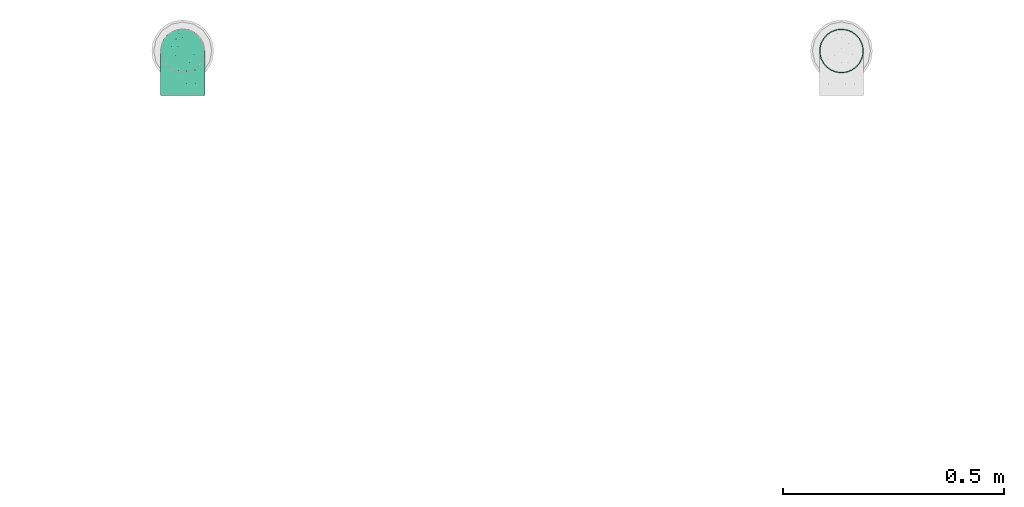
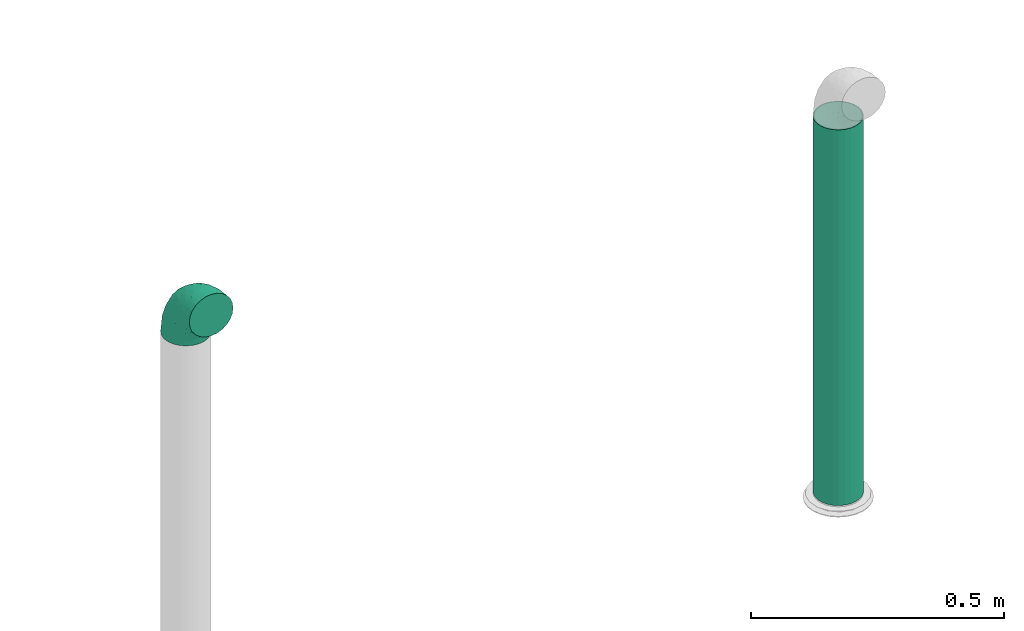
# One storey, part 77 of 103: 1 flow fitting, 1 flow segment.
"""IFC2X3 building model written with IfcOpenShell, lengths in millimetres."""

from ifc_helpers import new_model, entity, si_unit, converted_unit, derived_unit, direction, frame, origin_with_axes, origin_2d_with_axis, place, context, subcontext, project, spatial, hollow_circle, extrude, open_shell, surface_model, source, transform, mapped, material, layer, layer_set, layer_usage, type_object, element, save


model = new_model("IFC2X3")

# Units and contexts
model_context = context("Model", 3, precision=1e-05, world=origin_with_axes(), true_north=direction((0.0, 1.0)))
body_context = subcontext(model_context, "Body", "Model", "MODEL_VIEW")
ifc_project = project(units=[si_unit("AREAUNIT", "SQUARE_METRE"), si_unit("VOLUMEUNIT", "CUBIC_METRE", prefix="DECI"), si_unit("TIMEUNIT", "SECOND"), si_unit("THERMODYNAMICTEMPERATUREUNIT", "DEGREE_CELSIUS"), si_unit("PRESSUREUNIT", "PASCAL"), si_unit("MASSUNIT", "GRAM", prefix="KILO"), si_unit("LENGTHUNIT", "METRE", prefix="MILLI"), si_unit("POWERUNIT", "WATT"), si_unit("ELECTRICCURRENTUNIT", "AMPERE"), si_unit("ELECTRICVOLTAGEUNIT", "VOLT"), derived_unit("VOLUMETRICFLOWRATEUNIT", [(si_unit("VOLUMEUNIT", "CUBIC_METRE", prefix="DECI"), 1), (si_unit("TIMEUNIT", "SECOND"), -1)]), derived_unit("LINEARVELOCITYUNIT", [(si_unit("LENGTHUNIT", "METRE"), 1), (si_unit("TIMEUNIT", "SECOND"), -1)]), derived_unit("MASSDENSITYUNIT", [(si_unit("MASSUNIT", "GRAM", prefix="KILO"), 1), (si_unit("VOLUMEUNIT", "CUBIC_METRE"), -1)]), converted_unit("PLANEANGLEUNIT", "DEGREE", entity("IfcRatioMeasure", 0.01745), si_unit("PLANEANGLEUNIT", "RADIAN"), dimensions=[0, 0, 0, 0, 0, 0, 0])], contexts=[model_context])

# Site, building, storey
site_placement = place(None, origin_with_axes())
site = spatial("IfcSite", under=ifc_project, at=site_placement, CompositionType="ELEMENT")
building_placement = place(site_placement, origin_with_axes())
building = spatial("IfcBuilding", under=site, at=building_placement, Name="mc-building", CompositionType="ELEMENT")
storey_placement = place(building_placement, frame((0.0, 0.0, 5900.0), z_axis=(0.0, 0.0, 1.0), x_axis=(1.0, 0.0, 0.0)))
storey = spatial("IfcBuildingStorey", under=building, at=storey_placement, Name="3. Korrus", CompositionType="ELEMENT", Elevation=5900.0)

# Flow fitting
duct_fitting_type = type_object("IfcDuctFittingType", Name="BU", PredefinedType="BEND")
shared_shape_1 = source(origin_with_axes(), body_context, "Body", "SurfaceModel", [
    surface_model("IfcShellBasedSurfaceModel", [(-100.0, 0.0, -50.0), (-100.0, -12.94095, -48.29629), (-100.0, 12.94095, -48.29629), (-100.0, 48.29629, 12.94095), (-100.0, 25.0, -43.30127), (-100.0, 43.30127, -25.0), (-100.0, 35.35534, -35.35534), (-100.0, -50.0, 0.0), (-100.0, -48.29629, 12.94095), (-100.0, -35.35534, -35.35534), (-100.0, -25.0, -43.30127), (-100.0, -48.29629, -12.94095), (-100.0, -43.30127, -25.0), (-100.0, 48.29629, -12.94095), (-100.0, 43.30127, 25.0), (-100.0, 35.35534, 35.35534), (-100.0, -12.94095, 48.29629), (-100.0, 25.0, 43.30127), (-100.0, 12.94095, 48.29629), (-100.0, -43.30127, 25.0), (-100.0, -35.35534, 35.35534), (-100.0, -25.0, 43.30127), (-100.0, 0.0, 50.0), (-100.0, 50.0, 0.0), (-12.94095, 100.0, -48.29629), (-50.0, 100.0, 0.0), (0.0, 100.0, -50.0), (-25.0, 100.0, -43.30127), (-35.35534, 100.0, -35.35534), (-43.30127, 100.0, -25.0), (35.35534, 100.0, -35.35534), (48.29629, 100.0, 12.94095), (25.0, 100.0, -43.30127), (12.94095, 100.0, -48.29629), (43.30127, 100.0, -25.0), (48.29629, 100.0, -12.94095), (50.0, 100.0, 0.0), (-48.29629, 100.0, -12.94095), (-48.29629, 100.0, 12.94095), (-43.30127, 100.0, 25.0), (-35.35534, 100.0, 35.35534), (0.0, 100.0, 50.0), (-25.0, 100.0, 43.30127), (-12.94095, 100.0, 48.29629), (43.30127, 100.0, 25.0), (35.35534, 100.0, 35.35534), (25.0, 100.0, 43.30127), (12.94095, 100.0, 48.29629), (-58.37939, 44.26324, 39.66767), (-69.67318, 34.70921, 41.41807), (-54.95374, 29.60867, 47.22379), (-69.0983, 4.89435, 50.0), (-81.95957, 10.85813, 49.17398), (-71.45436, 24.34004, 46.19398), (-63.80701, 16.86512, 49.12211), (-68.68567, 49.28345, 29.46598), (-84.79657, 41.61468, 30.43807), (-87.38486, 20.12422, 46.19398), (-19.0983, 41.22148, 50.0), (-16.69326, 64.07661, 49.13167), (-29.12893, 54.21835, 47.49497), (-58.07867, 67.98053, 16.35576), (-67.87621, 57.34916, 18.11021), (-57.82431, 60.07162, 27.24983), (-90.54273, 47.92896, 16.84479), (-84.64671, 51.44953, 9.54872), (-89.28706, 52.13093, 0.0), (-48.57141, 84.18266, 19.13417), (-80.49866, 49.85236, 19.13417), (-10.78328, 82.03604, 49.18466), (-4.89435, 69.0983, 50.0), (-52.13093, 89.28706, 0.0), (-51.49654, 84.66157, 9.29171), (-41.22148, 19.0983, 50.0), (-40.55308, 40.55308, 47.39468), (-84.25895, 32.24248, 39.66767), (-20.22969, 86.73423, 46.19398), (-32.70712, 82.37816, 39.66767), (-39.73574, 63.26064, 40.42863), (-24.76101, 70.36257, 46.19398), (-52.07527, 72.10209, 22.70672), (-53.34351, 76.64659, 14.58596), (-75.39343, 54.87419, 11.74349), (-45.34852, 49.56196, 42.93091), (-67.79776, 60.76145, 8.68857), (-41.23466, 86.33892, 30.43807), (-53.80602, 80.86583, 0.0), (-46.83364, 71.48109, 30.43807), (-59.22534, 72.75524, 0.0), (-51.32111, 56.42251, 36.03223), (-80.86583, 53.80602, 0.0), (-64.64466, 64.64466, 0.0), (-72.75524, 59.22534, 0.0), (-86.30081, 41.24353, -30.43807), (-84.6487, 51.45583, -9.51467), (-90.59087, 47.99544, -16.6365), (-82.00387, 32.80624, -39.66767), (-72.72667, 42.3343, -34.47953), (-69.0983, 4.89435, -50.0), (-66.13967, 17.89682, -48.73206), (-41.22148, 19.0983, -50.0), (-19.92688, 59.20071, -48.9627), (-4.89435, 69.0983, -50.0), (-19.0983, 41.22148, -50.0), (-32.19887, 84.44786, -39.66767), (-82.82099, 10.02515, -49.28938), (-41.61468, 84.79657, -30.43807), (-82.27704, 21.1002, -46.19398), (-64.48049, 30.28903, -45.01594), (-71.3903, 57.59661, -10.6727), (-22.65007, 76.4146, -46.19398), (-80.71765, 49.76775, -19.13417), (-63.27201, 52.13514, -30.43807), (-66.69474, 56.78794, -20.8562), (-57.71875, 61.44646, -25.88117), (-51.44953, 84.64671, -9.54872), (-49.85236, 80.49866, -19.13417), (-49.18799, 68.95983, -29.38061), (-52.50869, 28.2692, -48.00802), (-47.92896, 90.54273, -16.84479), (-11.48103, 81.33005, -49.0827), (-31.33477, 60.4193, -45.4939), (-39.98518, 39.98518, -47.65708), (-59.80479, 65.98498, -16.07996), (-63.94971, 39.6845, -40.19955), (-52.24546, 47.26788, -40.83149), (-55.20497, 74.81068, -11.71424), (-38.49923, 67.49589, -39.66767), (-52.04722, 57.72873, -34.6201), (-73.59404, 48.69992, -26.65479), (-47.57173, 4.1387, -49.13473), (29.5722, 42.84907, -27.71428), (13.52969, 19.02651, -30.72245), (13.59601, 32.77977, -38.42312), (27.49134, 63.71843, -37.951), (17.59627, 59.41659, -43.64098), (-63.95523, -42.22253, -17.81382), (-42.84907, -29.5722, -27.71428), (-25.90272, -27.798, -14.9099), (-4.1387, 47.57173, -49.13473), (-20.45037, 20.45037, -48.41225), (-68.61243, -10.20497, -47.82471), (-73.92917, -46.87327, -9.07697), (-73.47057, -38.0442, -29.22414), (-63.71843, -27.49134, -37.951), (-32.77977, -13.59601, -38.42312), (-8.32573, -9.86545, -25.36336), (-59.41659, -17.59627, -43.64098), (10.20497, 68.61244, -47.82471), (3.58524, 39.93936, -45.93923), (-12.17948, 12.17948, -43.75507), (-39.93936, -3.58524, -45.93923), (44.88888, 61.17714, 0.0), (38.05536, 43.47505, -9.02401), (45.64165, 67.74269, -9.06645), (17.21028, 10.65055, -15.96581), (-25.0, -29.90381, 0.0), (-1.12135, -11.13977, -11.07369), (38.0442, 73.47057, -29.22414), (32.46004, 37.55825, -18.52941), (42.22253, 63.95523, -17.81382), (29.90381, 25.0, 0.0), (6.06602, -6.06602, 0.0), (-61.17714, -44.88888, 0.0), (-45.78423, -39.05041, -8.65056), (-4.97501, 4.97501, -36.29915), (-63.95523, -42.22253, 17.81382), (-67.74269, -45.64165, 9.06645), (-37.55825, -32.46004, 18.52941), (-42.84907, -29.5722, 27.71428), (-73.47057, -38.0442, 29.22414), (-4.1387, 47.57173, 49.13473), (10.20497, 68.61244, 47.82471), (-39.93936, -3.58524, 45.93923), (-59.41659, -17.59627, 43.64098), (-32.77977, -13.59601, 38.42312), (-63.71843, -27.49134, 37.951), (-10.65055, -17.21028, 15.96581), (27.798, 25.90272, 14.9099), (11.13977, 1.12135, 11.07369), (46.87327, 73.92917, 9.07697), (39.05041, 45.78423, 8.65056), (-68.61243, -10.20497, 47.82471), (-47.57173, 4.1387, 49.13473), (3.58524, 39.93936, 45.93923), (-20.45037, 20.45037, 48.41225), (-12.17948, 12.17948, 43.75507), (9.86545, 8.32574, 25.36336), (-19.02651, -13.52969, 30.72245), (-43.47505, -38.05536, 9.02401), (29.5722, 42.84907, 27.71428), (42.22253, 63.95523, 17.81382), (38.0442, 73.47057, 29.22414), (27.49134, 63.71843, 37.951), (17.59627, 59.41659, 43.64098), (13.59601, 32.77977, 38.42312), (-4.97501, 4.97501, 36.29915)], [open_shell([[[0, 1, 2]], [[2, 3, 4]], [[5, 6, 3]], [[3, 6, 4]], [[2, 7, 8]], [[9, 7, 10]], [[1, 10, 7]], [[11, 7, 12]], [[9, 12, 7]], [[7, 2, 1]], [[13, 5, 3]], [[14, 3, 2]], [[15, 14, 2]], [[16, 17, 2]], [[15, 2, 17]], [[18, 17, 16]], [[8, 19, 2]], [[2, 19, 20]], [[2, 20, 21]], [[16, 2, 21]], [[16, 22, 18]], [[23, 13, 3]], [[24, 25, 26]], [[27, 25, 24]], [[25, 28, 29]], [[27, 28, 25]], [[30, 26, 31]], [[26, 30, 32]], [[32, 33, 26]], [[30, 31, 34]], [[35, 34, 31]], [[35, 31, 36]], [[37, 25, 29]], [[26, 38, 39]], [[26, 39, 40]], [[41, 40, 42]], [[40, 41, 26]], [[41, 42, 43]], [[26, 44, 31]], [[45, 44, 26]], [[46, 45, 26]], [[47, 46, 26]], [[47, 26, 41]], [[26, 25, 38]], [[48, 49, 50]], [[22, 51, 52]], [[53, 54, 50]], [[55, 56, 49]], [[56, 14, 15]], [[18, 57, 17]], [[58, 59, 60]], [[61, 62, 63]], [[3, 64, 65]], [[53, 52, 54]], [[3, 65, 66]], [[67, 39, 38]], [[56, 68, 64]], [[65, 64, 68]], [[69, 59, 70]], [[38, 71, 72]], [[73, 58, 74]], [[75, 49, 56]], [[76, 69, 43]], [[53, 57, 52]], [[77, 78, 79]], [[42, 76, 43]], [[43, 69, 41]], [[55, 68, 56]], [[15, 17, 75]], [[76, 77, 79]], [[80, 67, 81]], [[62, 82, 68]], [[60, 78, 83]], [[62, 84, 82]], [[85, 77, 40]], [[81, 67, 72]], [[86, 72, 71]], [[87, 85, 67]], [[61, 81, 88]], [[77, 42, 40]], [[78, 77, 87]], [[15, 75, 56]], [[83, 89, 48]], [[85, 40, 39]], [[62, 68, 55]], [[89, 87, 63]], [[83, 48, 50]], [[57, 75, 17]], [[49, 75, 53]], [[67, 85, 39]], [[87, 77, 85]], [[63, 62, 55]], [[89, 55, 48]], [[80, 63, 87]], [[66, 65, 90]], [[66, 23, 3]], [[84, 91, 92]], [[92, 90, 82]], [[65, 82, 90]], [[61, 84, 62]], [[92, 82, 84]], [[68, 82, 65]], [[3, 14, 64]], [[56, 64, 14]], [[38, 25, 71]], [[81, 72, 86]], [[38, 72, 67]], [[91, 61, 88]], [[80, 81, 61]], [[63, 80, 61]], [[67, 80, 87]], [[77, 76, 42]], [[79, 59, 69]], [[79, 69, 76]], [[41, 69, 70]], [[60, 59, 79]], [[58, 70, 59]], [[78, 60, 79]], [[58, 60, 74]], [[52, 57, 18]], [[75, 57, 53]], [[22, 52, 18]], [[52, 51, 54]], [[51, 73, 54]], [[50, 73, 74]], [[73, 50, 54]], [[50, 74, 83]], [[60, 83, 74]], [[89, 83, 78]], [[87, 89, 78]], [[55, 89, 63]], [[50, 49, 53]], [[55, 49, 48]], [[81, 86, 88]], [[91, 84, 61]], [[6, 5, 93]], [[90, 94, 66]], [[13, 94, 95]], [[96, 93, 97]], [[98, 99, 100]], [[96, 4, 6]], [[101, 102, 103]], [[28, 27, 104]], [[2, 105, 0]], [[104, 106, 28]], [[99, 105, 107]], [[108, 107, 96]], [[90, 109, 94]], [[107, 2, 4]], [[13, 66, 94]], [[27, 24, 110]], [[109, 111, 94]], [[112, 113, 114]], [[37, 115, 71]], [[116, 106, 117]], [[99, 118, 100]], [[116, 115, 119]], [[37, 119, 115]], [[24, 120, 110]], [[121, 110, 101]], [[119, 106, 116]], [[101, 110, 120]], [[122, 103, 100]], [[117, 123, 116]], [[124, 125, 108]], [[115, 116, 126]], [[106, 29, 28]], [[26, 102, 120]], [[127, 104, 110]], [[97, 124, 96]], [[125, 122, 118]], [[128, 127, 125]], [[96, 6, 93]], [[115, 126, 86]], [[117, 106, 127]], [[111, 113, 129]], [[95, 93, 5]], [[97, 129, 112]], [[110, 104, 27]], [[106, 104, 127]], [[96, 107, 4]], [[99, 107, 108]], [[99, 108, 118]], [[105, 99, 98]], [[112, 114, 128]], [[121, 125, 127]], [[13, 23, 66]], [[109, 90, 92]], [[94, 111, 95]], [[91, 123, 109]], [[129, 113, 112]], [[93, 95, 111]], [[5, 13, 95]], [[71, 115, 86]], [[71, 25, 37]], [[123, 91, 88]], [[126, 116, 123]], [[123, 88, 126]], [[86, 126, 88]], [[37, 29, 119]], [[106, 119, 29]], [[129, 93, 111]], [[124, 112, 125]], [[0, 105, 98]], [[107, 105, 2]], [[125, 118, 108]], [[100, 118, 122]], [[93, 129, 97]], [[113, 111, 109]], [[109, 123, 113]], [[114, 123, 117]], [[123, 114, 113]], [[128, 114, 117]], [[127, 128, 117]], [[112, 128, 125]], [[103, 122, 101]], [[110, 121, 127]], [[101, 122, 121]], [[125, 121, 122]], [[26, 120, 24]], [[101, 120, 102]], [[96, 124, 108]], [[92, 91, 109]], [[112, 124, 97]], [[100, 130, 98]], [[131, 132, 133]], [[32, 134, 135]], [[136, 137, 138]], [[139, 140, 103]], [[98, 141, 0]], [[142, 11, 136]], [[143, 144, 137]], [[7, 11, 142]], [[137, 145, 146]], [[144, 147, 145]], [[143, 136, 12]], [[12, 136, 11]], [[9, 143, 12]], [[148, 149, 139]], [[9, 10, 144]], [[10, 1, 147]], [[130, 141, 98]], [[103, 140, 100]], [[148, 135, 149]], [[150, 151, 140]], [[152, 153, 154]], [[130, 140, 151]], [[148, 26, 33]], [[147, 1, 141]], [[155, 146, 132]], [[156, 138, 157]], [[134, 30, 158]], [[150, 140, 149]], [[158, 30, 34]], [[30, 134, 32]], [[153, 159, 160]], [[131, 160, 159]], [[144, 145, 137]], [[36, 152, 154]], [[146, 138, 137]], [[155, 161, 162]], [[158, 160, 131]], [[133, 149, 135]], [[156, 163, 164]], [[163, 142, 164]], [[139, 103, 102]], [[153, 152, 161]], [[34, 35, 160]], [[162, 157, 155]], [[132, 165, 133]], [[157, 146, 155]], [[140, 130, 100]], [[141, 130, 151]], [[141, 151, 147]], [[141, 1, 0]], [[102, 26, 148]], [[140, 139, 149]], [[102, 148, 139]], [[135, 33, 32]], [[151, 150, 145]], [[10, 147, 144]], [[151, 145, 147]], [[145, 165, 146]], [[135, 148, 33]], [[133, 135, 134]], [[131, 133, 134]], [[133, 165, 150]], [[133, 150, 149]], [[145, 150, 165]], [[132, 131, 159]], [[146, 165, 132]], [[160, 158, 34]], [[134, 158, 131]], [[144, 143, 9]], [[136, 143, 137]], [[155, 153, 161]], [[154, 153, 160]], [[153, 155, 159]], [[132, 159, 155]], [[160, 35, 154]], [[36, 154, 35]], [[164, 136, 138]], [[7, 142, 163]], [[136, 164, 142]], [[156, 164, 138]], [[156, 157, 162]], [[146, 157, 138]], [[19, 8, 166]], [[7, 163, 167]], [[168, 169, 166]], [[166, 169, 170]], [[171, 172, 70]], [[173, 174, 175]], [[21, 176, 174]], [[177, 156, 162]], [[176, 20, 170]], [[170, 20, 19]], [[161, 178, 179]], [[152, 180, 181]], [[182, 173, 183]], [[22, 16, 182]], [[184, 185, 186]], [[183, 185, 73]], [[183, 73, 51]], [[177, 187, 188]], [[189, 168, 166]], [[187, 178, 190]], [[20, 176, 21]], [[161, 152, 181]], [[44, 191, 31]], [[44, 45, 192]], [[192, 191, 44]], [[180, 36, 31]], [[193, 194, 195]], [[46, 47, 194]], [[193, 195, 190]], [[193, 45, 46]], [[172, 41, 70]], [[185, 58, 73]], [[189, 163, 156]], [[163, 189, 167]], [[70, 58, 171]], [[184, 171, 185]], [[169, 188, 175]], [[180, 31, 191]], [[192, 193, 190]], [[191, 190, 178]], [[182, 174, 173]], [[194, 47, 172]], [[190, 195, 187]], [[186, 185, 173]], [[162, 179, 177]], [[188, 196, 175]], [[179, 187, 177]], [[185, 171, 58]], [[172, 171, 184]], [[172, 184, 194]], [[172, 47, 41]], [[51, 22, 182]], [[185, 183, 173]], [[51, 182, 183]], [[174, 16, 21]], [[184, 186, 195]], [[46, 194, 193]], [[184, 195, 194]], [[195, 196, 187]], [[174, 182, 16]], [[175, 174, 176]], [[169, 175, 176]], [[175, 196, 186]], [[175, 186, 173]], [[195, 186, 196]], [[188, 169, 168]], [[187, 196, 188]], [[166, 170, 19]], [[176, 170, 169]], [[193, 192, 45]], [[191, 192, 190]], [[177, 189, 156]], [[167, 189, 166]], [[189, 177, 168]], [[188, 168, 177]], [[166, 8, 167]], [[7, 167, 8]], [[181, 191, 178]], [[36, 180, 152]], [[191, 181, 180]], [[161, 181, 178]], [[161, 179, 162]], [[187, 179, 178]]])]),
])
flow_fitting_placement = place(storey_placement, frame((22488.52671, 12733.41275, 3468.0), z_axis=(1.0, 0.0, 0.0), x_axis=(0.0, 0.0, 1.0)))
element("IfcFlowFitting", 1, at=flow_fitting_placement, inside=storey, type_object=duct_fitting_type, Name="BU", context=body_context, shape_type="MappedRepresentation", body=[
    mapped(shared_shape_1, transform((0.0, 0.0, 0.0), scale=1.0)),
])

# Flow segment
ifc_material = material(Name="FZ1")
ifc_layer = layer(ifc_material, 0.0)
ifc_layer_set = layer_set([ifc_layer], Name="FZ1")
ifc_layer_usage = layer_usage(ifc_layer_set, "AXIS1", "POSITIVE", 0.0)
duct_segment_type = type_object("IfcDuctSegmentType", PredefinedType="RIGIDSEGMENT")
shared_shape_2 = source(origin_with_axes(), body_context, "Body", "SweptSolid", [
    extrude(hollow_circle(Radius=50.0, WallThickness=2.0, at=origin_2d_with_axis()), frame((0.0, 0.0, 0.0), z_axis=(1.0, 0.0, 0.0), x_axis=(0.0, 1.0, 0.0)), (0.0, 0.0, 1.0), 906.0),
])
flow_segment_placement = place(storey_placement, frame((23976.55606, 12733.41275, 2461.97044), z_axis=(1.0, 0.0, 0.0), x_axis=(0.0, 0.0, 1.0)))
element("IfcFlowSegment", 2, at=flow_segment_placement, inside=storey, type_object=duct_segment_type, material=ifc_layer_usage, context=body_context, shape_type="MappedRepresentation", body=[
    mapped(shared_shape_2, transform((0.0, 0.0, 0.0), scale=1.0)),
])

save(model, "model.ifc")
